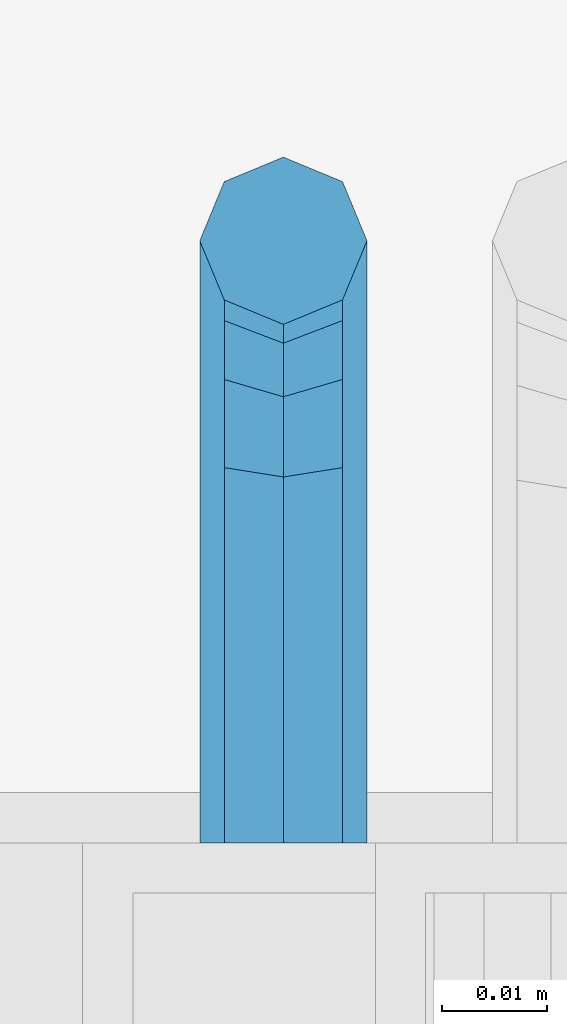
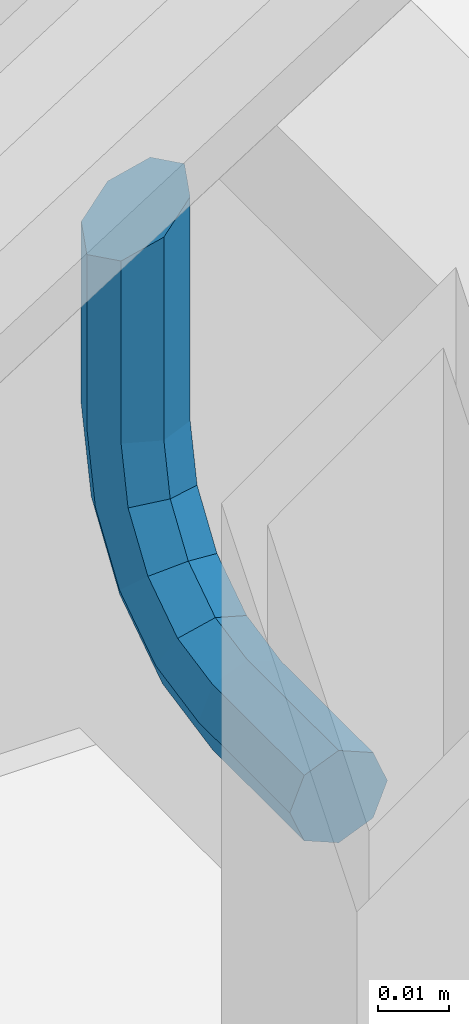
# One storey, part 1188 of 1876: 1 beam, 1 element without a shape of its own.
"""IFC2X3 building model written with IfcOpenShell, lengths in millimetres."""

from ifc_helpers import new_model, si_unit, frame, origin_with_axes, place, context, subcontext, project, spatial, faceted_brep, material, type_object, element, aggregate, save


model = new_model("IFC2X3")

# Units and contexts
model_context = context("Model", 3, precision=1e-05, world=origin_with_axes())
body_context = subcontext(model_context, "Body", "Model", "MODEL_VIEW")
ifc_project = project(units=[si_unit("LENGTHUNIT", "METRE", prefix="MILLI"), si_unit("AREAUNIT", "SQUARE_METRE"), si_unit("VOLUMEUNIT", "CUBIC_METRE"), si_unit("MASSUNIT", "GRAM", prefix="KILO"), si_unit("TIMEUNIT", "SECOND"), si_unit("PLANEANGLEUNIT", "RADIAN"), si_unit("SOLIDANGLEUNIT", "STERADIAN"), si_unit("THERMODYNAMICTEMPERATUREUNIT", "DEGREE_CELSIUS"), si_unit("LUMINOUSINTENSITYUNIT", "LUMEN")], contexts=[model_context])

# Site, building, storey
site_placement = place(None, origin_with_axes())
site = spatial("IfcSite", under=ifc_project, at=site_placement, CompositionType="ELEMENT")
building_placement = place(site_placement, origin_with_axes())
building = spatial("IfcBuilding", under=site, at=building_placement, Name="Undefined", CompositionType="ELEMENT")
storey_placement = place(building_placement, origin_with_axes())
storey = spatial("IfcBuildingStorey", under=building, at=storey_placement, Name="Undefined", CompositionType="ELEMENT", Elevation=0.0)

# Assembly, beam
assembly_placement = place(storey_placement, origin_with_axes())
assembly = element("IfcElementAssembly", 1, at=assembly_placement, inside=storey, Name="RAIL", AssemblyPlace="NOTDEFINED", PredefinedType="RIGID_FRAME")
ifc_material = material(Name="STEEL/A36")
beam_type = type_object("IfcBeamType", PredefinedType="NOTDEFINED")
beam_placement = place(assembly_placement, frame((5080.00006207416, -5715.00000114554, 2485.22883435439), z_axis=(1.0, 0.0, 0.0), x_axis=(0.0, 1.0, 0.0)))
beam = element("IfcBeam", 2, at=beam_placement, type_object=beam_type, material=ifc_material, Name="BRACKET", context=body_context, shape_type="Brep", body=[
    faceted_brep([(0.0, -5.61266007566822, 5.61266007566883), (0.0, 0.0, 7.9375), (0.0, 5.61266007566822, 5.61266007566883), (0.0, 7.9375, 0.0), (0.0, 5.61266007566822, -5.61266007566883), (0.0, 0.0, -7.9375), (0.0, -5.61266007566822, -5.61266007566883), (0.0, -7.9375, 0.0), (25.7500019073486, -5.6126600756694, -5.61266007566974), (25.7500019073486, -7.93750000000102, -1.81898940354586e-12), (25.7500019073486, -5.61266007566837, 5.61266007566746), (25.7500019073486, 6.82121026329696e-13, 7.93750000000045), (25.7500019073486, 5.6126600756694, 5.61266007566928), (25.7500019073486, 7.93750000000102, 9.09494701772928e-13), (25.7500019073486, 5.61266007566837, -5.61266007566837), (25.7500019073486, -6.82121026329696e-13, -7.93750000000091), (37.7662607879083, 2.39017891888352, -7.93750166859718), (39.9141330299508, -2.79524175511915, -5.61265950959933), (40.803811282025, -4.94311113920139, 1.49169682117645e-06), (39.9141340902152, -2.79523647837323, 5.6126606417356), (37.7662622873477, 2.39018638132939, 7.937498331401), (35.6183900453052, 7.57560705533251, 5.61265617240315), (34.728711793231, 9.7234764394143, -4.82889299746603e-06), (35.6183889850417, 7.57560177858613, -5.61266397893178), (43.9844035873093, 13.1655940203409, -5.61266788133162), (47.9531531815637, 9.19684280310457, -7.93750642036139), (42.3404944911981, 14.8095070346781, -8.37947573018027e-06), (43.9844055464218, 13.1655998976785, 5.6126522700024), (47.9531559521674, 9.19685111491481, 7.93749357963588), (51.9219055464218, 5.22809989767848, 5.61265504060611), (53.565814642534, 3.58418688334177, -4.46125068265246e-06), (51.9219035873093, 5.2280940203409, -5.61266511072881), (54.7598170657875, 19.3837351967577, -7.93751353188054), (59.9452393627726, 17.2358645776962, -5.61267349341051), (49.5743958290659, 21.5316086226071, -5.61267372168732), (47.4265250864628, 22.4212897326429, -1.36932976602111e-05), (49.5743983887696, 21.5316153987928, 5.61264642964761), (54.7598206857547, 19.3837447797314, 7.93748646811673), (59.9452419224763, 17.235871353882, 5.61264665792351), (62.0931126650794, 16.3461902438462, -1.33704661493539e-05), (62.7626602162454, 31.3999957002966, -5.61268338145874), (65.0875015258789, 31.3999996185225, -2.19204903260106e-05), (57.1499995667664, 31.399994077316, -7.93752192048851), (51.5373400649087, 31.3999957002989, -5.61268061085502), (49.2125015258789, 31.3999996185239, -1.99613778022467e-05), (51.5373428355124, 31.4000035367485, 5.61263954047809), (57.1500034849914, 31.4000051597295, 7.93747807950785), (62.7626629868482, 31.4000035367467, 5.61263676987437), (65.0875015258789, 66.3398661827996, -4.63121787106502e-05), (62.7626620592855, 69.9005606306541, 5.6126108200142), (57.1500021229667, 71.3754489730973, 7.93745017245874), (51.5373419079488, 69.9005612114365, 5.61261173549065), (49.2125015258789, 66.3398666704393, -4.55435210824362e-05), (51.5373408209025, 62.7791718437898, -5.61270327280181), (57.1500005856506, 61.3042833925019, -7.93754279681616), (62.7626609722383, 62.779171045318, -5.61270453141788)], [[[0, 1, 2, 3, 4, 5, 6, 7]], [[7, 6, 8, 9]], [[0, 7, 9, 10]], [[1, 0, 10, 11]], [[2, 1, 11, 12]], [[3, 2, 12, 13]], [[4, 3, 13, 14]], [[5, 4, 14, 15]], [[6, 5, 15, 8]], [[8, 15, 16, 17]], [[9, 8, 17, 18]], [[10, 9, 18, 19]], [[11, 10, 19, 20]], [[12, 11, 20, 21]], [[13, 12, 21, 22]], [[14, 13, 22, 23]], [[15, 14, 23, 16]], [[23, 24, 25, 16]], [[22, 26, 24, 23]], [[21, 27, 26, 22]], [[20, 28, 27, 21]], [[19, 29, 28, 20]], [[18, 30, 29, 19]], [[17, 31, 30, 18]], [[16, 25, 31, 17]], [[25, 32, 33, 31]], [[24, 34, 32, 25]], [[26, 35, 34, 24]], [[27, 36, 35, 26]], [[28, 37, 36, 27]], [[29, 38, 37, 28]], [[30, 39, 38, 29]], [[31, 33, 39, 30]], [[33, 40, 41, 39]], [[32, 42, 40, 33]], [[34, 43, 42, 32]], [[35, 44, 43, 34]], [[36, 45, 44, 35]], [[37, 46, 45, 36]], [[38, 47, 46, 37]], [[39, 41, 47, 38]], [[47, 41, 48, 49]], [[46, 47, 49, 50]], [[45, 46, 50, 51]], [[44, 45, 51, 52]], [[43, 44, 52, 53]], [[42, 43, 53, 54]], [[40, 42, 54, 55]], [[41, 40, 55, 48]], [[54, 53, 52, 51, 50, 49, 48, 55]]]),
])
aggregate(assembly, [beam])

save(model, "model.ifc")
